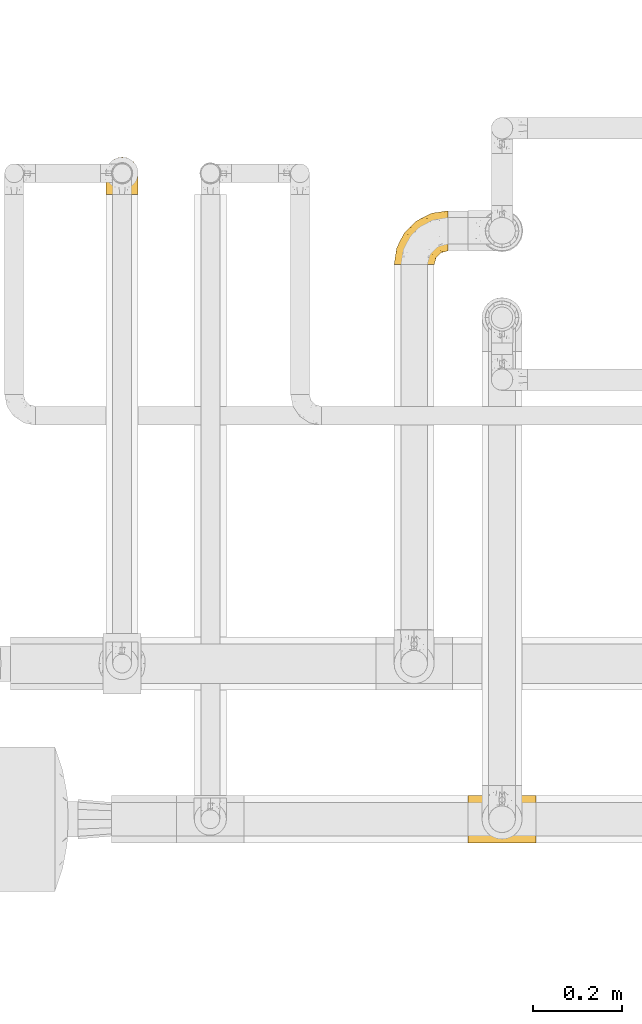
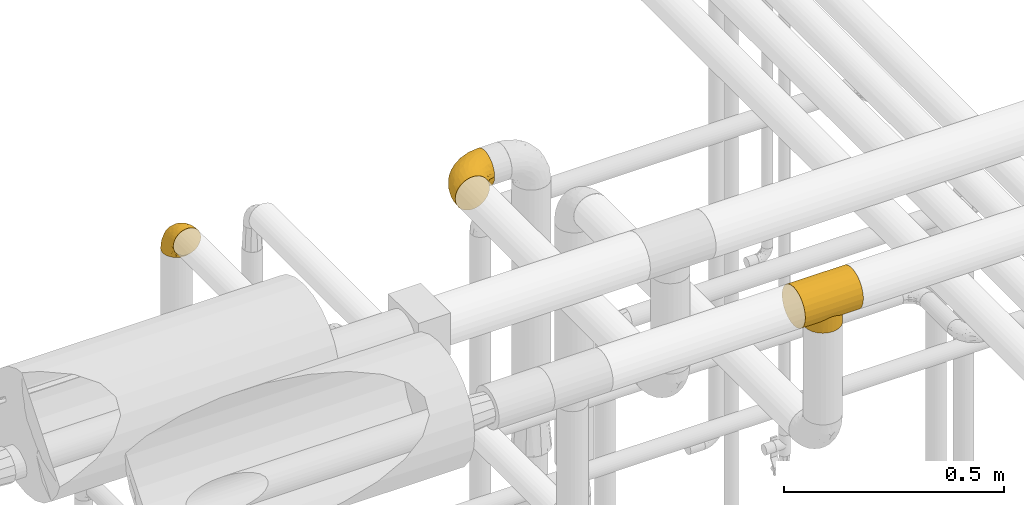
# One storey, part 128 of 827: 3 coverings.
"""IFC2X3 building model written with IfcOpenShell, lengths in millimetres."""

import ifcopenshell
import ifcopenshell.guid

model = None  # the IFC model being written
_history = None  # IfcOwnerHistory: only IFC2X3 demands one
_inside = {}  # id of a spatial element -> (the spatial element, [elements in it])
_under = {}  # id of a project, library or spatial element -> (it, [spatial elements below it])
_declared = {}  # id of a project -> (the project, [libraries it declares])
_typed = {}  # id of a type object -> (the type object, [elements of that type])
_made_of = {}  # id of a material, layer set ... -> (it, [elements and type objects made of it])


def new_model(schema):
    """Start an empty IFC model of exactly this schema.

    Asked for "IFC4X3", IfcOpenShell would pick the latest addendum, in which some entities
    have other attributes; the version numbers below select the first issue.
    IFC2X3 requires an IfcOwnerHistory on every rooted entity: one is made here for all.
    """
    global model, _history
    if schema == "IFC4X3":
        model = ifcopenshell.file(schema_version=(4, 3, 0, 0))
    else:
        model = ifcopenshell.file(schema=schema)
    _inside.clear()
    _under.clear()
    _declared.clear()
    _typed.clear()
    _made_of.clear()
    _history = None
    if model.schema == "IFC2X3":
        org = make("IfcOrganization", Name="unknown")
        user = make(
            "IfcPersonAndOrganization",
            ThePerson=make("IfcPerson", FamilyName="unknown"),
            TheOrganization=org,
        )
        app = make(
            "IfcApplication",
            ApplicationDeveloper=org,
            Version="unknown",
            ApplicationFullName="unknown",
            ApplicationIdentifier="unknown",
        )
        _history = make(
            "IfcOwnerHistory",
            OwningUser=user,
            OwningApplication=app,
            ChangeAction="ADDED",
            CreationDate=0,
        )
    return model


def make(cls, **values):
    """One entity of the class cls with the attributes given. An attribute that is None is left unset."""
    return model.create_entity(
        cls, **{name: value for name, value in values.items() if value is not None}
    )


def entity(cls, *values):
    """Any entity or typed value of the class cls, its attributes in the order of the schema. None: left unset."""
    e = model.create_entity(cls)
    for i, value in enumerate(values):
        if value is not None:
            e[i] = value
    return e


def rooted(cls, **values):
    """An entity with a GlobalId (a new one), such as an element, a storey or a relation."""
    return make(cls, GlobalId=ifcopenshell.guid.new(), OwnerHistory=_history, **values)


def si_unit(unit_type, name, prefix=None):
    """IfcSIUnit, for example si_unit("LENGTHUNIT", "METRE", prefix="MILLI")."""
    return make("IfcSIUnit", UnitType=unit_type, Prefix=prefix, Name=name)


def converted_unit(unit_type, name, factor, base, dimensions=None, offset=None):
    """IfcConversionBasedUnit, such as the inch: factor (a typed value) times the base unit."""
    return make(
        "IfcConversionBasedUnit"
        if offset is None
        else "IfcConversionBasedUnitWithOffset",
        ConversionOffset=offset,
        Dimensions=None
        if dimensions is None
        else entity("IfcDimensionalExponents", *dimensions),
        UnitType=unit_type,
        Name=name,
        ConversionFactor=make(
            "IfcMeasureWithUnit", ValueComponent=factor, UnitComponent=base
        ),
    )


def derived_unit(unit_type, elements):
    """IfcDerivedUnit: a product of units, each with its exponent."""
    return make(
        "IfcDerivedUnit",
        Elements=[
            make("IfcDerivedUnitElement", Unit=unit, Exponent=power)
            for unit, power in elements
        ],
        UnitType=unit_type,
    )


def assignment(units):
    """IfcUnitAssignment: the units of a project."""
    return None if units is None else make("IfcUnitAssignment", Units=units)


def point(xyz):
    """IfcCartesianPoint."""
    return None if xyz is None else make("IfcCartesianPoint", Coordinates=xyz)


def direction(xyz):
    """IfcDirection."""
    return None if xyz is None else make("IfcDirection", DirectionRatios=xyz)


def frame(location, z_axis=None, x_axis=None):
    """IfcAxis2Placement3D, a coordinate frame: its origin and axes. An axis left out is left unset."""
    return make(
        "IfcAxis2Placement3D",
        Location=point(location),
        Axis=direction(z_axis),
        RefDirection=direction(x_axis),
    )


def origin():
    """The frame at (0, 0, 0) with its axes left unset."""
    return frame((0.0, 0.0, 0.0))


def place(relative_to, where):
    """IfcLocalPlacement: puts the frame where relative to a parent placement (None: the world)."""
    return make(
        "IfcLocalPlacement", PlacementRelTo=relative_to, RelativePlacement=where
    )


def context(
    kind, dimensions, precision=None, world=None, true_north=None, identifier=None
):
    """IfcGeometricRepresentationContext, for example the 3D "Model" context."""
    return make(
        "IfcGeometricRepresentationContext",
        ContextIdentifier=identifier,
        ContextType=kind,
        CoordinateSpaceDimension=dimensions,
        Precision=precision,
        WorldCoordinateSystem=world,
        TrueNorth=true_north,
    )


def subcontext(parent, identifier, kind, view, scale=None):
    """IfcGeometricRepresentationSubContext, for example "Body" below "Model"."""
    return make(
        "IfcGeometricRepresentationSubContext",
        ContextIdentifier=identifier,
        ContextType=kind,
        ParentContext=parent,
        TargetScale=scale,
        TargetView=view,
    )


def project(units=None, contexts=None):
    """IfcProject with its units and contexts."""
    return rooted(
        "IfcProject",
        Name="project",
        RepresentationContexts=contexts,
        UnitsInContext=assignment(units),
    )


def spatial(cls, under=None, at=None, **own):
    """A site, building, storey or space (cls), placed at a placement, below another one or the project."""
    s = rooted(cls, ObjectPlacement=at, **own)
    if under is not None:
        _under.setdefault(under.id(), (under, []))[1].append(s)
    return s


def faces_of(points, faces, orient=None, outer=None):
    """IfcFace entities. A face is a list of loops; a loop is a list of indices into points, from 0.

    orient and outer hold one flag for each loop. By default every Orientation is true, the
    first loop of a face is its IfcFaceOuterBound and the others are IfcFaceBound.
    """
    made = []
    for i, loops in enumerate(faces):
        bounds = []
        for j, loop in enumerate(loops):
            is_outer = j == 0 if outer is None else outer[i][j]
            bounds.append(
                make(
                    "IfcFaceOuterBound" if is_outer else "IfcFaceBound",
                    Bound=make("IfcPolyLoop", Polygon=[points[k] for k in loop]),
                    Orientation=True if orient is None else orient[i][j],
                )
            )
        made.append(make("IfcFace", Bounds=bounds))
    return made


def faceted_brep(points, faces, orient=None, outer=None, voids=None):
    """IfcFacetedBrep: a solid bounded by flat faces; with voids (closed shells), ...WithVoids."""
    shared = [point(p) for p in points]
    hull = make("IfcClosedShell", CfsFaces=faces_of(shared, faces, orient, outer))
    if voids is None:
        return make("IfcFacetedBrep", Outer=hull)
    return make(
        "IfcFacetedBrepWithVoids",
        Outer=hull,
        Voids=[
            make(cls, CfsFaces=faces_of(shared, fs, o, b)) for cls, fs, o, b in voids
        ],
    )


def shape(context_of_items, identifier, shape_type, items):
    """IfcShapeRepresentation: the items that make up one representation, for example the "Body"."""
    return make(
        "IfcShapeRepresentation",
        ContextOfItems=context_of_items,
        RepresentationIdentifier=identifier,
        RepresentationType=shape_type,
        Items=items,
    )


def made_of(thing, what):
    """Note that an element or type object is made of a material, layer set ...; save() writes the relation."""
    if what is not None:
        _made_of.setdefault(what.id(), (what, []))[1].append(thing)
    return thing


def element(
    cls,
    number,
    at=None,
    inside=None,
    cuts=None,
    type_object=None,
    material=None,
    context=None,
    identifier="Body",
    shape_type=None,
    held_by="IfcProductDefinitionShape",
    body=None,
    shapes=None,
    **own,
):
    """One element of the class cls, such as IfcWall. Its Tag is "e" and its number.

    at: its placement. inside: the storey or other place that contains it. cuts: it is an
    opening in that element (IfcRelVoidsElement). A single representation is given by context,
    identifier, shape_type and body (its items); several are given by shapes. held_by: the class
    of the entity that holds the representations. save() writes the other relations.
    """
    e = rooted(cls, Tag="e%d" % number, ObjectPlacement=at, **own)
    if body is not None:
        shapes = [shape(context, identifier, shape_type, body)]
    if shapes is not None:
        e.Representation = make(held_by, Representations=shapes)
    if inside is not None:
        _inside.setdefault(inside.id(), (inside, []))[1].append(e)
    if cuts is not None:
        rooted(
            "IfcRelVoidsElement", RelatingBuildingElement=cuts, RelatedOpeningElement=e
        )
    if type_object is not None:
        _typed.setdefault(type_object.id(), (type_object, []))[1].append(e)
    return made_of(e, material)


def aggregate(whole, parts):
    """IfcRelAggregates: a whole, such as a stair, and the parts it consists of."""
    return rooted("IfcRelAggregates", RelatingObject=whole, RelatedObjects=parts)


def save(model, path):
    """Write the relations noted so far, then the file.

    IfcRelAggregates (storeys below a building ...), IfcRelContainedInSpatialStructure (elements
    in a storey), IfcRelDefinesByType, IfcRelAssociatesMaterial and IfcRelDeclares: one each for
    every whole, place, type object, material and project.
    """
    for whole, parts in _under.values():
        aggregate(whole, parts)
    for where, things in _inside.values():
        rooted(
            "IfcRelContainedInSpatialStructure",
            RelatedElements=things,
            RelatingStructure=where,
        )
    for kind, things in _typed.values():
        rooted("IfcRelDefinesByType", RelatedObjects=things, RelatingType=kind)
    for what, things in _made_of.values():
        rooted("IfcRelAssociatesMaterial", RelatedObjects=things, RelatingMaterial=what)
    for by, libraries in _declared.values():
        rooted("IfcRelDeclares", RelatingContext=by, RelatedDefinitions=libraries)
    model.write(path)


model = new_model("IFC2X3")

# Units and contexts
model_context = context("Model", 3, precision=0.01, world=origin(), true_north=direction((6.12303176911189e-17, 1.0)))
body_context = subcontext(model_context, "Body", "Model", "MODEL_VIEW")
ifc_project = project(units=[si_unit("LENGTHUNIT", "METRE", prefix="MILLI"), si_unit("AREAUNIT", "SQUARE_METRE"), si_unit("VOLUMEUNIT", "CUBIC_METRE"), converted_unit("PLANEANGLEUNIT", "DEGREE", entity("IfcRatioMeasure", 0.0174532925199433), si_unit("PLANEANGLEUNIT", "RADIAN"), dimensions=[0, 0, 0, 0, 0, 0, 0]), si_unit("MASSUNIT", "GRAM", prefix="KILO"), derived_unit("MASSDENSITYUNIT", [(si_unit("MASSUNIT", "GRAM", prefix="KILO"), 1), (si_unit("LENGTHUNIT", "METRE"), -3)]), derived_unit("MOMENTOFINERTIAUNIT", [(si_unit("LENGTHUNIT", "METRE"), 4)]), si_unit("TIMEUNIT", "SECOND"), si_unit("FREQUENCYUNIT", "HERTZ"), si_unit("THERMODYNAMICTEMPERATUREUNIT", "DEGREE_CELSIUS"), derived_unit("THERMALTRANSMITTANCEUNIT", [(si_unit("MASSUNIT", "GRAM", prefix="KILO"), 1), (si_unit("THERMODYNAMICTEMPERATUREUNIT", "KELVIN"), -1), (si_unit("TIMEUNIT", "SECOND"), -3)]), derived_unit("VOLUMETRICFLOWRATEUNIT", [(si_unit("LENGTHUNIT", "METRE"), 3), (si_unit("TIMEUNIT", "SECOND"), -1)]), derived_unit("MASSFLOWRATEUNIT", [(si_unit("MASSUNIT", "GRAM", prefix="KILO"), 1), (si_unit("TIMEUNIT", "SECOND"), -1)]), derived_unit("ROTATIONALFREQUENCYUNIT", [(si_unit("TIMEUNIT", "SECOND"), -1)]), si_unit("ELECTRICCURRENTUNIT", "AMPERE"), si_unit("ELECTRICVOLTAGEUNIT", "VOLT"), si_unit("POWERUNIT", "WATT"), si_unit("FORCEUNIT", "NEWTON", prefix="KILO"), si_unit("ILLUMINANCEUNIT", "LUX"), si_unit("LUMINOUSFLUXUNIT", "LUMEN"), si_unit("LUMINOUSINTENSITYUNIT", "CANDELA"), derived_unit("USERDEFINED", [(si_unit("MASSUNIT", "GRAM", prefix="KILO"), -1), (si_unit("LENGTHUNIT", "METRE"), -2), (si_unit("TIMEUNIT", "SECOND"), 3), (si_unit("LUMINOUSFLUXUNIT", "LUMEN"), 1)]), derived_unit("LINEARVELOCITYUNIT", [(si_unit("LENGTHUNIT", "METRE"), 1), (si_unit("TIMEUNIT", "SECOND"), -1)]), si_unit("PRESSUREUNIT", "PASCAL"), derived_unit("USERDEFINED", [(si_unit("LENGTHUNIT", "METRE"), -2), (si_unit("MASSUNIT", "GRAM", prefix="KILO"), 1), (si_unit("TIMEUNIT", "SECOND"), -2)]), derived_unit("LINEARFORCEUNIT", [(si_unit("MASSUNIT", "GRAM", prefix="KILO"), 1), (si_unit("LENGTHUNIT", "METRE"), 1), (si_unit("TIMEUNIT", "SECOND"), -2), (si_unit("LENGTHUNIT", "METRE"), -1)]), derived_unit("PLANARFORCEUNIT", [(si_unit("MASSUNIT", "GRAM", prefix="KILO"), 1), (si_unit("LENGTHUNIT", "METRE"), 1), (si_unit("TIMEUNIT", "SECOND"), -2), (si_unit("LENGTHUNIT", "METRE"), -2)])], contexts=[model_context])

# Site, building, storey
site_placement = place(None, origin())
site = spatial("IfcSite", under=ifc_project, at=site_placement, CompositionType="ELEMENT")
building_placement = place(site_placement, origin())
building = spatial("IfcBuilding", under=site, at=building_placement, CompositionType="ELEMENT")
storey_placement = place(building_placement, frame((0.0, 0.0, 28200.0)))
storey = spatial("IfcBuildingStorey", under=building, at=storey_placement, Name="08", CompositionType="ELEMENT", Elevation=28200.0)

# Coverings
covering_1_placement = place(storey_placement, frame((17846.29, 14345.35, 2729.98)))
element("IfcCovering", 1, at=covering_1_placement, inside=storey, Name=":ADSK_", ObjectType=":ADSK_", PredefinedType="INSULATION", context=body_context, shape_type="Brep", body=[
    faceted_brep([(152.0, 68.38, 121.24), (152.0, 54.65, 123.05), (152.0, 40.91, 121.24), (152.0, 28.12, 115.94), (152.0, 17.13, 107.51), (152.0, 8.7, 96.53), (152.0, 3.4, 83.73), (152.0, 1.6, 70.0), (152.0, 3.4, 56.27), (152.0, 8.7, 43.48), (152.0, 17.13, 32.49), (152.0, 22.63, 28.27), (152.0, 28.12, 24.06), (152.0, 34.52, 21.41), (152.0, 40.91, 18.76), (152.0, 47.78, 17.85), (152.0, 54.65, 16.95), (152.0, 61.51, 17.85), (152.0, 68.38, 18.76), (152.0, 74.77, 21.41), (152.0, 81.17, 24.06), (152.0, 86.66, 28.27), (152.0, 92.16, 32.49), (152.0, 100.59, 43.48), (152.0, 105.89, 56.27), (152.0, 107.7, 70.0), (152.0, 105.89, 83.73), (152.0, 100.59, 96.53), (152.0, 92.16, 107.51), (152.0, 81.17, 115.94), (0.0, 1.6, 70.0), (0.0, 3.4, 83.73), (0.0, 8.7, 96.53), (0.0, 17.13, 107.51), (0.0, 28.12, 115.94), (0.0, 40.91, 121.24), (0.0, 54.65, 123.05), (0.0, 68.38, 121.24), (0.0, 81.17, 115.94), (0.0, 92.16, 107.51), (0.0, 100.59, 96.53), (0.0, 105.89, 83.73), (0.0, 107.7, 70.0), (0.0, 105.89, 56.27), (0.0, 100.59, 43.48), (0.0, 92.16, 32.49), (0.0, 86.66, 28.27), (0.0, 81.17, 24.06), (0.0, 74.77, 21.41), (0.0, 68.38, 18.76), (0.0, 61.51, 17.85), (0.0, 54.65, 16.95), (0.0, 47.78, 17.85), (0.0, 40.91, 18.76), (0.0, 34.52, 21.41), (0.0, 28.12, 24.06), (0.0, 22.63, 28.27), (0.0, 17.13, 32.49), (0.0, 8.7, 43.48), (0.0, 3.4, 56.27), (76.0, 9.5, 42.15), (48.07, 19.17, 30.55), (56.12, 14.11, 35.78), (118.05, 39.05, 19.55), (116.24, 34.17, 21.06), (65.44, 10.75, 40.21), (41.21, 25.86, 25.44), (95.88, 14.11, 35.78), (86.56, 10.75, 40.21), (120.51, 49.29, 17.5), (121.15, 54.65, 16.95), (30.85, 54.65, 16.95), (31.49, 49.29, 17.5), (103.93, 19.17, 30.55), (110.79, 25.86, 25.44), (35.76, 34.17, 21.06), (32.14, 43.94, 18.04), (33.95, 39.05, 19.55), (119.86, 43.94, 18.04), (31.49, 60.0, 17.5), (32.14, 65.35, 18.04), (35.76, 75.12, 21.06), (41.21, 83.43, 25.44), (48.07, 90.12, 30.55), (33.95, 70.24, 19.55), (119.86, 65.35, 18.04), (120.51, 60.0, 17.5), (116.24, 75.12, 21.06), (110.79, 83.43, 25.44), (118.05, 70.24, 19.55), (56.12, 95.18, 35.78), (76.0, 99.8, 42.15), (65.44, 98.54, 40.21), (95.88, 95.18, 35.78), (103.93, 90.12, 30.55), (86.56, 98.54, 40.21), (44.07, 22.72, 0.0), (36.9, 32.07, 0.0), (32.39, 42.96, 0.0), (30.85, 54.65, 0.0), (32.39, 66.33, 0.0), (36.9, 77.22, 0.0), (44.07, 86.57, 0.0), (53.42, 93.75, 0.0), (64.31, 98.26, 0.0), (76.0, 99.8, 0.0), (87.69, 98.26, 0.0), (98.57, 93.75, 0.0), (107.93, 86.57, 0.0), (115.1, 77.22, 0.0), (119.61, 66.33, 0.0), (121.15, 54.65, 0.0), (119.61, 42.96, 0.0), (115.1, 32.07, 0.0), (107.93, 22.72, 0.0), (98.57, 15.54, 0.0), (87.69, 11.03, 0.0), (76.0, 9.5, 0.0), (64.31, 11.03, 0.0), (53.42, 15.54, 0.0)], [[[0, 1, 2, 3, 4, 5, 6, 7, 8, 9, 10, 11, 12, 13, 14, 15, 16, 17, 18, 19, 20, 21, 22, 23, 24, 25, 26, 27, 28, 29]], [[30, 31, 32, 33, 34, 35, 36, 37, 38, 39, 40, 41, 42, 43, 44, 45, 46, 47, 48, 49, 50, 51, 52, 53, 54, 55, 56, 57, 58, 59]], [[34, 33, 4, 3]], [[1, 36, 35, 2]], [[2, 35, 34, 3]], [[5, 32, 31, 6]], [[6, 31, 30, 7]], [[4, 33, 32, 5]], [[59, 8, 7, 30]], [[58, 60, 59]], [[57, 61, 62]], [[57, 56, 61]], [[63, 13, 64]], [[65, 58, 62]], [[61, 56, 66]], [[62, 58, 57]], [[65, 60, 58]], [[8, 60, 9]], [[67, 9, 68]], [[16, 69, 70]], [[71, 72, 51]], [[10, 9, 67]], [[73, 10, 67]], [[74, 12, 11]], [[68, 9, 60]], [[59, 60, 8]], [[75, 55, 54]], [[66, 55, 75]], [[76, 53, 52]], [[54, 53, 77]], [[13, 63, 14]], [[51, 72, 52]], [[76, 52, 72]], [[77, 75, 54]], [[11, 10, 73]], [[53, 76, 77]], [[12, 64, 13]], [[64, 12, 74]], [[15, 78, 69]], [[11, 73, 74]], [[16, 15, 69]], [[15, 14, 78]], [[78, 14, 63]], [[66, 56, 55]], [[50, 79, 51]], [[80, 50, 49]], [[48, 47, 81]], [[82, 81, 47]], [[45, 83, 46]], [[49, 84, 80]], [[50, 80, 79]], [[85, 17, 86]], [[86, 16, 70]], [[51, 79, 71]], [[87, 88, 20]], [[16, 86, 17]], [[18, 89, 19]], [[88, 21, 20]], [[19, 89, 87]], [[82, 47, 46]], [[84, 48, 81]], [[83, 45, 90]], [[83, 82, 46]], [[90, 45, 44]], [[48, 84, 49]], [[91, 44, 43]], [[91, 92, 44]], [[44, 92, 90]], [[43, 42, 25, 24]], [[85, 18, 17]], [[22, 93, 23]], [[87, 20, 19]], [[22, 21, 94]], [[22, 94, 93]], [[93, 95, 23]], [[18, 85, 89]], [[91, 23, 95]], [[23, 91, 24]], [[24, 91, 43]], [[94, 21, 88]], [[26, 41, 40, 27]], [[27, 40, 39, 28]], [[42, 41, 26, 25]], [[29, 38, 37, 0]], [[0, 37, 36, 1]], [[28, 39, 38, 29]], [[96, 97, 98, 99, 100, 101, 102, 103, 104, 105, 106, 107, 108, 109, 110, 111, 112, 113, 114, 115, 116, 117, 118, 119]], [[76, 99, 98]], [[75, 98, 97]], [[99, 76, 72, 71]], [[66, 75, 97]], [[98, 75, 77, 76]], [[97, 96, 66]], [[61, 96, 119]], [[62, 119, 118]], [[65, 118, 117]], [[61, 119, 62]], [[65, 62, 118]], [[60, 65, 117]], [[96, 61, 66]], [[68, 117, 116]], [[67, 116, 115]], [[60, 117, 68]], [[68, 116, 67]], [[115, 73, 67]], [[115, 114, 73]], [[74, 114, 113]], [[64, 113, 112]], [[78, 112, 111]], [[64, 74, 113]], [[111, 70, 69, 78]], [[112, 78, 63, 64]], [[114, 74, 73]], [[85, 111, 110]], [[87, 110, 109]], [[111, 85, 86, 70]], [[88, 87, 109]], [[110, 87, 89, 85]], [[109, 108, 88]], [[94, 108, 107]], [[93, 107, 106]], [[95, 106, 105]], [[94, 107, 93]], [[95, 93, 106]], [[91, 95, 105]], [[108, 94, 88]], [[92, 105, 104]], [[90, 104, 103]], [[91, 105, 92]], [[92, 104, 90]], [[103, 83, 90]], [[103, 102, 83]], [[82, 102, 101]], [[81, 101, 100]], [[80, 100, 99]], [[81, 82, 101]], [[99, 71, 79, 80]], [[100, 80, 84, 81]], [[102, 82, 83]]]),
])
covering_2_placement = place(storey_placement, frame((17678.0, 15644.75, 2353.26)))
element("IfcCovering", 2, at=covering_2_placement, inside=storey, Name=":ADSK_", ObjectType=":ADSK_", PredefinedType="INSULATION", context=body_context, shape_type="Brep", body=[
    faceted_brep([(36.69, 1.6, 90.76), (27.15, 1.6, 87.42), (18.59, 1.62, 82.04), (11.44, 1.63, 74.89), (6.06, 1.65, 66.33), (2.73, 1.67, 56.79), (1.6, 1.69, 46.75), (2.73, 1.71, 36.69), (6.07, 1.73, 27.15), (11.45, 1.75, 18.59), (18.6, 1.76, 11.44), (27.16, 1.77, 6.06), (36.7, 1.78, 2.73), (46.75, 1.78, 1.6), (56.8, 1.78, 2.73), (66.34, 1.77, 6.07), (74.9, 1.76, 11.45), (82.05, 1.75, 18.6), (87.43, 1.73, 27.16), (90.76, 1.71, 36.7), (91.9, 1.69, 46.75), (90.76, 1.67, 56.8), (87.42, 1.65, 66.34), (82.04, 1.63, 74.9), (74.89, 1.62, 82.05), (66.33, 1.6, 87.43), (56.79, 1.6, 90.76), (46.75, 1.6, 91.9), (122.75, 34.1, 35.13), (122.75, 38.63, 24.25), (122.75, 45.83, 14.91), (122.75, 55.19, 7.75), (122.75, 66.09, 3.27), (122.75, 77.78, 1.75), (122.75, 89.46, 3.31), (122.75, 100.34, 7.85), (122.75, 109.68, 15.04), (122.75, 116.83, 24.41), (122.75, 121.32, 35.3), (122.75, 122.84, 46.99), (122.75, 121.28, 58.68), (122.75, 116.74, 69.56), (122.75, 109.55, 78.89), (122.75, 100.18, 86.05), (122.75, 89.28, 90.54), (122.75, 77.6, 92.05), (122.75, 65.91, 90.49), (122.75, 55.03, 85.96), (122.75, 45.7, 78.76), (122.75, 38.54, 69.4), (122.75, 34.05, 58.5), (122.75, 32.54, 46.81), (24.73, 72.9, 46.89), (29.08, 77.25, 55.36), (38.13, 86.3, 46.92), (85.31, 116.91, 46.98), (93.59, 118.56, 54.77), (100.54, 119.32, 46.99), (63.54, 105.2, 59.84), (38.98, 85.43, 62.24), (50.71, 89.37, 72.04), (93.33, 116.19, 62.88), (75.2, 105.11, 71.54), (100.46, 112.19, 73.16), (41.6, 22.96, 91.24), (80.86, 89.92, 86.49), (94.87, 103.41, 81.1), (67.96, 93.63, 79.68), (52.16, 51.42, 90.78), (52.1, 67.72, 86.98), (36.74, 43.54, 87.47), (17.11, 30.94, 76.93), (23.24, 23.59, 83.77), (29.18, 50.09, 81.13), (52.53, 30.68, 91.95), (60.77, 43.01, 91.98), (69.01, 55.34, 92.01), (100.68, 83.48, 91.2), (103.79, 94.96, 87.77), (16.37, 57.37, 56.64), (7.52, 39.13, 46.82), (7.31, 30.72, 60.46), (93.66, 71.81, 92.04), (102.83, 73.63, 92.04), (112.01, 75.46, 92.05), (18.17, 51.62, 67.97), (71.97, 73.13, 90.49), (9.83, 23.21, 69.61), (5.11, 23.89, 46.79), (45.97, 75.62, 80.06), (48.88, 12.33, 91.92), (50.71, 21.51, 91.94), (22.83, 50.49, 75.09), (51.54, 99.7, 46.95), (81.33, 63.57, 92.02), (31.74, 21.27, 88.57), (32.48, 69.58, 72.79), (68.42, 108.3, 46.96), (25.33, 68.48, 63.11), (16.13, 56.01, 46.86), (92.29, 19.42, 66.24), (94.12, 15.83, 56.63), (100.97, 26.2, 59.94), (95.91, 62.78, 91.08), (107.9, 63.65, 90.34), (87.24, 24.37, 76.69), (95.46, 28.5, 71.63), (90.41, 33.56, 80.05), (74.17, 39.47, 89.61), (83.77, 51.05, 90.07), (76.72, 10.96, 81.34), (84.44, 14.58, 74.59), (76.42, 22.23, 84.19), (90.07, 57.05, 90.48), (99.69, 54.01, 87.93), (61.74, 29.19, 91.04), (58.16, 18.86, 90.99), (112.6, 52.85, 85.24), (110.45, 31.54, 58.17), (107.32, 28.4, 46.8), (108.48, 43.03, 78.48), (66.63, 16.91, 88.25), (115.23, 36.03, 66.14), (105.79, 33.96, 68.67), (89.6, 10.03, 63.8), (69.39, 25.94, 88.47), (66.99, 35.62, 90.68), (102.31, 47.47, 83.89), (99.54, 38.29, 78.05), (55.27, 11.7, 91.24), (82.03, 30.15, 83.52), (94.71, 12.21, 46.77), (96.03, 17.11, 46.78), (94.11, 44.41, 84.75), (84.21, 39.84, 86.41), (101.67, 22.76, 46.79), (112.22, 29.72, 46.8), (108.48, 43.16, 15.19), (102.31, 47.62, 9.78), (99.54, 38.42, 15.59), (94.11, 44.56, 8.92), (110.46, 31.59, 35.45), (76.74, 11.1, 12.2), (50.71, 21.69, 1.64), (58.17, 19.03, 2.57), (55.27, 11.89, 2.29), (94.12, 15.87, 36.93), (92.3, 19.49, 27.34), (100.98, 26.26, 33.67), (69.41, 26.12, 5.12), (76.44, 22.38, 9.4), (66.65, 17.08, 5.31), (115.24, 36.11, 27.5), (102.83, 73.82, 1.74), (112.01, 75.64, 1.75), (82.05, 30.28, 10.11), (87.25, 24.49, 16.91), (112.6, 53.01, 8.46), (107.9, 63.83, 3.4), (93.66, 72.0, 1.74), (95.48, 28.6, 21.99), (89.6, 10.09, 29.74), (60.77, 43.19, 1.68), (69.01, 55.52, 1.71), (74.17, 39.64, 4.04), (48.88, 12.52, 1.62), (84.45, 14.69, 18.97), (95.91, 62.96, 2.67), (90.07, 57.23, 3.23), (81.33, 63.76, 1.72), (61.75, 29.38, 2.57), (83.77, 51.23, 3.62), (84.21, 39.99, 7.25), (52.53, 30.86, 1.65), (90.42, 33.68, 13.58), (67.0, 35.79, 2.95), (99.69, 54.17, 5.78), (105.8, 34.05, 24.96), (94.87, 103.55, 12.81), (80.86, 90.09, 7.36), (67.95, 93.76, 14.19), (75.17, 105.2, 22.38), (50.65, 89.42, 21.79), (71.97, 73.31, 3.29), (52.08, 67.85, 6.78), (32.46, 69.64, 20.96), (38.98, 85.49, 31.58), (103.79, 95.13, 6.1), (100.68, 83.66, 2.63), (63.54, 105.25, 34.08), (93.32, 116.26, 31.08), (93.59, 118.6, 39.2), (100.44, 112.3, 20.79), (52.17, 51.59, 2.91), (36.75, 43.69, 6.19), (41.61, 23.13, 2.34), (7.31, 30.78, 33.14), (17.12, 31.06, 16.67), (16.37, 57.42, 37.07), (23.26, 23.74, 9.8), (18.17, 51.69, 25.71), (25.33, 68.54, 30.64), (9.84, 23.3, 23.95), (29.19, 50.23, 12.55), (22.84, 50.6, 18.59), (31.75, 21.43, 5.0), (45.96, 75.72, 13.72), (29.07, 77.27, 38.44)], [[[0, 1, 2, 3, 4, 5, 6, 7, 8, 9, 10, 11, 12, 13, 14, 15, 16, 17, 18, 19, 20, 21, 22, 23, 24, 25, 26, 27]], [[28, 29, 30, 31, 32, 33, 34, 35, 36, 37, 38, 39, 40, 41, 42, 43, 44, 45, 46, 47, 48, 49, 50, 51]], [[52, 53, 54]], [[55, 56, 57]], [[58, 59, 60]], [[61, 62, 63]], [[27, 64, 0]], [[65, 66, 67]], [[41, 40, 61]], [[68, 69, 70]], [[66, 43, 42]], [[63, 42, 41]], [[71, 72, 73]], [[72, 2, 1]], [[68, 74, 75, 76]], [[45, 44, 77]], [[43, 78, 44]], [[79, 80, 81]], [[77, 82, 83, 84, 45]], [[79, 81, 85]], [[71, 2, 72]], [[65, 86, 77]], [[4, 81, 5]], [[66, 65, 78]], [[4, 3, 87]], [[81, 88, 5]], [[63, 66, 42]], [[68, 70, 64]], [[67, 60, 89]], [[71, 3, 2]], [[64, 27, 90, 91, 74]], [[92, 71, 73]], [[40, 57, 56]], [[59, 93, 54]], [[86, 76, 94, 82]], [[1, 0, 95]], [[58, 62, 61]], [[60, 96, 89]], [[85, 81, 87]], [[56, 97, 58]], [[65, 67, 69]], [[87, 81, 4]], [[67, 89, 69]], [[61, 63, 41]], [[95, 72, 1]], [[73, 72, 70]], [[69, 73, 70]], [[73, 89, 96]], [[3, 71, 87]], [[85, 87, 71]], [[58, 61, 56]], [[59, 58, 93]], [[76, 86, 68]], [[69, 89, 73]], [[68, 86, 69]], [[65, 69, 86]], [[68, 64, 74]], [[95, 64, 70]], [[98, 79, 85]], [[79, 52, 99, 80]], [[66, 62, 67]], [[62, 58, 60]], [[62, 60, 67]], [[59, 98, 96]], [[59, 96, 60]], [[96, 85, 92]], [[88, 81, 80]], [[88, 6, 5]], [[66, 63, 62]], [[64, 95, 0]], [[72, 95, 70]], [[77, 44, 78]], [[86, 82, 77]], [[40, 39, 57]], [[96, 98, 85]], [[40, 56, 61]], [[66, 78, 43]], [[77, 78, 65]], [[79, 98, 53]], [[96, 92, 73]], [[85, 71, 92]], [[97, 56, 55]], [[97, 93, 58]], [[53, 98, 59]], [[54, 53, 59]], [[79, 53, 52]], [[100, 101, 102]], [[46, 45, 84, 83]], [[103, 104, 82]], [[82, 104, 83]], [[105, 106, 107]], [[108, 109, 76]], [[110, 111, 112]], [[103, 113, 114]], [[115, 74, 116]], [[48, 47, 117]], [[118, 102, 119]], [[49, 48, 120]], [[74, 91, 116]], [[116, 121, 115]], [[49, 122, 50]], [[123, 106, 102]], [[124, 111, 22]], [[125, 126, 115]], [[23, 22, 111]], [[24, 110, 121]], [[120, 127, 128]], [[90, 26, 129]], [[27, 26, 90]], [[121, 125, 115]], [[24, 121, 25]], [[130, 105, 107]], [[129, 25, 116]], [[21, 20, 131]], [[120, 123, 122]], [[112, 105, 130]], [[50, 118, 51]], [[21, 124, 22]], [[101, 131, 132]], [[117, 120, 48]], [[24, 23, 110]], [[127, 114, 133]], [[75, 108, 76]], [[107, 134, 130]], [[133, 114, 113]], [[129, 116, 91]], [[25, 121, 116]], [[121, 112, 125]], [[75, 74, 115]], [[101, 135, 102]], [[131, 101, 21]], [[101, 100, 124]], [[128, 127, 133]], [[119, 136, 51, 118]], [[104, 47, 46]], [[83, 104, 46]], [[117, 104, 114]], [[101, 124, 21]], [[111, 124, 100]], [[102, 118, 123]], [[133, 134, 107]], [[111, 110, 23]], [[114, 104, 103]], [[94, 76, 109]], [[121, 110, 112]], [[122, 118, 50]], [[134, 109, 108]], [[133, 107, 128]], [[112, 108, 125]], [[126, 125, 108]], [[108, 75, 126]], [[75, 115, 126]], [[109, 134, 133]], [[130, 108, 112]], [[108, 130, 134]], [[105, 112, 111]], [[111, 100, 105]], [[106, 105, 100]], [[102, 106, 100]], [[128, 106, 123]], [[90, 129, 91]], [[25, 129, 26]], [[104, 117, 47]], [[117, 114, 127]], [[82, 94, 103]], [[113, 94, 109]], [[94, 113, 103]], [[133, 113, 109]], [[106, 128, 107]], [[123, 120, 128]], [[120, 122, 49]], [[118, 122, 123]], [[135, 101, 132]], [[135, 119, 102]], [[117, 127, 120]], [[30, 29, 137]], [[138, 139, 140]], [[51, 136, 119, 141]], [[142, 17, 16]], [[143, 144, 145]], [[146, 147, 148]], [[149, 150, 151]], [[152, 29, 28]], [[33, 32, 153, 154]], [[150, 155, 156]], [[157, 31, 30]], [[153, 158, 159]], [[29, 152, 137]], [[148, 141, 119]], [[156, 160, 147]], [[148, 135, 146]], [[137, 138, 157]], [[19, 161, 146]], [[162, 163, 164]], [[14, 13, 165]], [[153, 32, 158]], [[147, 161, 166]], [[18, 17, 166]], [[167, 168, 169]], [[166, 150, 156]], [[151, 150, 142]], [[151, 170, 149]], [[151, 16, 15]], [[171, 140, 172]], [[165, 143, 145]], [[173, 170, 144]], [[142, 166, 17]], [[19, 131, 20]], [[144, 170, 151]], [[18, 161, 19]], [[173, 144, 143]], [[140, 139, 174]], [[171, 164, 163]], [[164, 172, 155]], [[151, 15, 144]], [[145, 15, 14]], [[173, 162, 170]], [[149, 175, 164]], [[19, 146, 131]], [[132, 131, 146]], [[160, 148, 147]], [[159, 158, 167]], [[135, 132, 146]], [[158, 32, 31]], [[157, 158, 31]], [[167, 158, 176]], [[166, 161, 18]], [[146, 161, 147]], [[148, 177, 141]], [[171, 168, 140]], [[171, 163, 169]], [[151, 142, 16]], [[166, 142, 150]], [[152, 141, 177]], [[51, 141, 28]], [[138, 140, 176]], [[172, 140, 174]], [[175, 149, 170]], [[164, 150, 149]], [[170, 162, 175]], [[162, 164, 175]], [[155, 172, 174]], [[171, 172, 164]], [[155, 174, 156]], [[164, 155, 150]], [[160, 156, 174]], [[147, 166, 156]], [[139, 160, 174]], [[148, 160, 177]], [[15, 145, 144]], [[165, 145, 14]], [[137, 157, 30]], [[158, 157, 176]], [[168, 167, 176]], [[169, 159, 167]], [[140, 168, 176]], [[169, 168, 171]], [[137, 177, 139]], [[160, 139, 177]], [[141, 152, 28]], [[137, 152, 177]], [[148, 119, 135]], [[157, 138, 176]], [[139, 138, 137]], [[178, 179, 180]], [[181, 180, 182]], [[179, 183, 184]], [[185, 186, 182]], [[187, 188, 179]], [[188, 33, 154, 153, 159]], [[181, 189, 190]], [[35, 34, 187]], [[191, 38, 190]], [[192, 178, 181]], [[179, 184, 180]], [[192, 190, 37]], [[37, 190, 38]], [[36, 35, 178]], [[54, 93, 186]], [[35, 187, 178]], [[193, 194, 184]], [[195, 173, 143, 165, 13]], [[195, 193, 173]], [[193, 163, 162, 173]], [[13, 12, 195]], [[8, 7, 196]], [[9, 197, 10]], [[198, 80, 99, 52]], [[196, 7, 88]], [[197, 199, 10]], [[182, 189, 181]], [[200, 198, 201]], [[200, 196, 198]], [[9, 8, 202]], [[194, 199, 203]], [[192, 37, 36]], [[80, 196, 88]], [[183, 159, 169, 163]], [[188, 34, 33]], [[202, 200, 197]], [[185, 203, 204]], [[202, 8, 196]], [[10, 199, 11]], [[12, 11, 205]], [[38, 191, 57]], [[189, 97, 191]], [[203, 199, 197]], [[205, 199, 194]], [[204, 203, 197]], [[184, 203, 206]], [[200, 202, 196]], [[197, 9, 202]], [[207, 54, 186]], [[97, 55, 191]], [[194, 203, 184]], [[183, 163, 193]], [[184, 206, 180]], [[183, 193, 184]], [[205, 195, 12]], [[193, 195, 194]], [[80, 198, 196]], [[207, 186, 201]], [[182, 180, 206]], [[181, 178, 180]], [[185, 182, 206]], [[182, 186, 189]], [[203, 185, 206]], [[185, 200, 201]], [[7, 6, 88]], [[178, 192, 36]], [[190, 192, 181]], [[199, 205, 11]], [[195, 205, 194]], [[159, 183, 188]], [[179, 188, 183]], [[57, 191, 55]], [[57, 39, 38]], [[189, 191, 190]], [[188, 187, 34]], [[178, 187, 179]], [[186, 93, 189]], [[197, 200, 204]], [[185, 204, 200]], [[189, 93, 97]], [[207, 198, 52]], [[185, 201, 186]], [[198, 207, 201]], [[54, 207, 52]]]),
])
covering_3_placement = place(storey_placement, frame((17030.57, 15802.19, 2350.4)))
element("IfcCovering", 3, at=covering_3_placement, inside=storey, Name=":ADSK_", ObjectType=":ADSK_", PredefinedType="INSULATION", context=body_context, shape_type="Brep", body=[
    faceted_brep([(74.0, 1.6, 49.6), (73.09, 1.6, 57.65), (70.41, 1.6, 65.31), (66.09, 1.6, 72.17), (60.36, 1.6, 77.9), (53.5, 1.6, 82.21), (45.85, 1.6, 84.89), (37.8, 1.6, 85.8), (29.74, 1.6, 84.89), (22.08, 1.6, 82.21), (15.22, 1.6, 77.89), (9.49, 1.6, 72.16), (5.18, 1.6, 65.3), (2.5, 1.6, 57.65), (1.6, 1.6, 49.6), (2.19, 1.6, 44.33), (2.5, 1.6, 41.54), (3.84, 1.6, 37.71), (5.18, 1.6, 33.88), (9.5, 1.6, 27.02), (15.23, 1.6, 21.29), (22.09, 1.6, 16.98), (29.74, 1.6, 14.3), (37.8, 1.6, 13.4), (45.85, 1.6, 14.3), (53.51, 1.6, 16.98), (60.37, 1.6, 21.3), (66.1, 1.6, 27.03), (70.41, 1.6, 33.89), (71.75, 1.6, 37.72), (73.09, 1.6, 41.54), (73.4, 1.6, 44.33), (28.43, 14.63, 1.6), (19.7, 18.25, 1.6), (12.2, 24.0, 1.6), (9.32, 27.75, 1.6), (6.45, 31.5, 1.6), (4.64, 35.86, 1.6), (2.83, 40.23, 1.6), (2.29, 44.31, 1.6), (1.94, 46.95, 1.6), (1.6, 49.6, 1.6), (2.83, 58.96, 1.6), (6.45, 67.7, 1.6), (12.2, 75.19, 1.6), (19.7, 80.95, 1.6), (28.43, 84.56, 1.6), (37.8, 85.8, 1.6), (47.16, 84.56, 1.6), (55.9, 80.95, 1.6), (63.39, 75.19, 1.6), (69.15, 67.7, 1.6), (72.76, 58.96, 1.6), (74.0, 49.6, 1.6), (73.3, 44.31, 1.6), (72.76, 40.23, 1.6), (70.95, 35.86, 1.6), (69.15, 31.5, 1.6), (66.27, 27.75, 1.6), (63.39, 24.0, 1.6), (55.9, 18.25, 1.6), (47.16, 14.63, 1.6), (37.8, 13.4, 1.6), (50.11, 59.61, 59.61), (37.8, 60.4, 60.4), (46.44, 51.32, 68.25), (37.8, 81.67, 27.61), (44.03, 82.49, 22.94), (37.8, 82.98, 19.4), (47.59, 73.87, 42.09), (57.17, 73.39, 33.53), (50.38, 81.11, 21.38), (58.65, 77.75, 16.47), (73.37, 16.46, 54.23), (71.27, 51.34, 38.23), (70.16, 63.37, 19.11), (66.97, 61.46, 36.76), (73.22, 54.83, 17.03), (74.0, 45.94, 19.96), (74.0, 47.42, 12.51), (74.0, 47.97, 9.78), (74.0, 48.51, 7.05), (64.86, 70.77, 21.71), (70.93, 15.75, 62.55), (45.19, 39.56, 75.89), (48.57, 21.48, 81.72), (54.32, 36.01, 74.04), (72.94, 34.58, 47.66), (74.0, 19.96, 45.94), (74.0, 23.86, 43.34), (74.0, 27.75, 40.74), (74.0, 31.64, 38.14), (74.0, 35.54, 35.54), (68.72, 46.13, 51.41), (73.34, 48.41, 30.21), (67.28, 16.74, 68.91), (61.7, 21.75, 74.03), (55.94, 16.31, 79.54), (37.8, 19.4, 82.98), (53.02, 48.77, 67.24), (57.31, 58.66, 55.48), (74.0, 7.05, 48.51), (74.0, 12.51, 47.42), (64.86, 34.87, 65.49), (59.15, 45.71, 64.99), (70.05, 30.95, 58.95), (55.98, 67.5, 45.7), (37.8, 75.69, 39.35), (63.54, 53.35, 53.72), (61.4, 64.73, 42.9), (37.8, 27.61, 81.67), (37.8, 51.09, 69.71), (37.8, 39.35, 75.69), (74.0, 38.14, 31.64), (74.0, 40.74, 27.75), (74.0, 43.34, 23.86), (37.8, 69.71, 51.09), (70.9, 30.92, 17.47), (69.2, 26.47, 18.36), (65.83, 24.1, 12.71), (73.31, 42.08, 7.84), (67.07, 27.56, 7.85), (62.53, 22.68, 6.14), (52.3, 12.9, 11.2), (54.94, 10.56, 14.99), (46.54, 9.38, 11.85), (72.14, 25.09, 29.62), (70.14, 24.56, 23.5), (73.22, 30.86, 29.66), (59.32, 15.4, 14.49), (56.36, 16.56, 9.51), (48.99, 14.21, 6.6), (58.36, 19.1, 6.61), (66.05, 6.65, 26.46), (61.56, 9.22, 20.83), (68.98, 13.56, 28.69), (73.26, 10.43, 41.38), (70.05, 32.68, 7.16), (73.39, 40.02, 16.97), (70.87, 33.01, 12.64), (61.17, 13.09, 18.4), (71.9, 11.85, 35.97), (65.19, 20.93, 16.38), (37.8, 6.64, 11.31), (46.04, 5.68, 13.68), (52.15, 5.7, 15.78), (66.57, 14.76, 24.06), (37.8, 9.94, 9.94), (73.34, 25.2, 35.3), (72.91, 19.66, 36.41), (37.8, 11.31, 6.64), (72.75, 39.13, 10.52), (66.28, 18.54, 20.86), (73.17, 37.21, 20.48), (72.08, 30.49, 23.69), (17.23, 19.1, 6.61), (26.6, 14.22, 6.59), (13.06, 22.68, 6.13), (1.6, 7.05, 48.51), (1.6, 12.51, 47.42), (29.56, 5.68, 13.67), (20.66, 10.57, 14.98), (23.45, 5.7, 15.78), (14.04, 9.22, 20.82), (1.6, 49.05, 4.32), (1.6, 47.42, 12.51), (1.6, 48.51, 7.05), (19.23, 16.56, 9.51), (23.3, 12.9, 11.19), (16.29, 15.39, 14.48), (8.09, 27.52, 10.19), (4.72, 33.0, 12.64), (5.54, 32.67, 7.16), (3.69, 11.86, 35.96), (2.84, 39.13, 10.52), (2.42, 37.21, 20.47), (4.69, 30.92, 17.47), (3.51, 30.49, 23.68), (2.2, 40.02, 16.97), (29.05, 9.38, 11.85), (2.29, 42.08, 7.84), (9.55, 6.65, 26.45), (14.43, 13.09, 18.39), (2.33, 10.43, 41.37), (9.32, 18.54, 20.85), (3.45, 25.08, 29.62), (5.45, 24.56, 23.5), (10.41, 20.93, 16.36), (2.81, 19.57, 35.87), (6.62, 13.56, 28.67), (1.6, 19.96, 45.94), (9.76, 24.1, 12.7), (9.03, 14.76, 24.04), (2.37, 30.85, 29.66), (4.15, 20.0, 30.95), (2.17, 25.27, 35.8), (1.6, 23.86, 43.34), (1.6, 40.74, 27.75), (1.6, 38.14, 31.64), (1.6, 45.94, 19.96), (1.6, 43.34, 23.86), (6.39, 26.46, 18.36), (1.6, 27.75, 40.74), (1.6, 35.54, 35.54), (1.6, 31.64, 38.14), (4.32, 51.33, 38.23), (2.37, 54.83, 17.03), (2.25, 48.41, 30.2), (16.43, 45.7, 64.98), (18.27, 58.67, 55.47), (12.04, 53.34, 53.71), (8.62, 61.46, 36.76), (6.87, 46.13, 51.4), (10.72, 34.86, 65.48), (2.64, 34.58, 47.66), (25.48, 59.61, 59.61), (19.59, 67.49, 45.69), (5.43, 63.37, 19.11), (31.57, 82.49, 22.94), (25.21, 81.11, 21.39), (5.53, 30.94, 58.94), (16.94, 77.75, 16.47), (10.73, 70.77, 21.71), (18.42, 73.39, 33.54), (21.26, 36.01, 74.04), (27.01, 21.48, 81.72), (30.39, 39.57, 75.89), (2.22, 16.45, 54.23), (13.88, 21.75, 74.02), (8.3, 16.74, 68.9), (28.0, 73.87, 42.09), (29.14, 51.31, 68.25), (22.56, 48.77, 67.24), (19.64, 16.32, 79.54), (14.18, 64.71, 42.91), (4.66, 15.75, 62.54)], [[[0, 1, 2, 3, 4, 5, 6, 7, 8, 9, 10, 11, 12, 13, 14, 15, 16, 17, 18, 19, 20, 21, 22, 23, 24, 25, 26, 27, 28, 29, 30, 31]], [[32, 33, 34, 35, 36, 37, 38, 39, 40, 41, 42, 43, 44, 45, 46, 47, 48, 49, 50, 51, 52, 53, 54, 55, 56, 57, 58, 59, 60, 61, 62]], [[63, 64, 65]], [[66, 67, 68]], [[69, 70, 71]], [[71, 70, 72]], [[73, 1, 0]], [[74, 75, 76]], [[49, 48, 71]], [[77, 78, 79, 80, 81, 53]], [[50, 82, 51]], [[72, 50, 49]], [[2, 1, 83]], [[84, 85, 86]], [[87, 88, 89, 90, 91, 92]], [[53, 52, 77]], [[93, 74, 76]], [[5, 85, 6]], [[94, 78, 77]], [[95, 3, 2]], [[95, 96, 3]], [[75, 51, 82]], [[85, 5, 97]], [[50, 72, 82]], [[97, 5, 4]], [[85, 98, 6]], [[94, 87, 92]], [[74, 77, 75]], [[99, 100, 63]], [[96, 4, 3]], [[73, 0, 101, 102, 88]], [[96, 103, 104]], [[48, 68, 67]], [[84, 99, 65]], [[105, 83, 73]], [[105, 95, 83]], [[100, 106, 63]], [[86, 96, 104]], [[97, 86, 85]], [[67, 107, 69]], [[100, 108, 109]], [[84, 110, 85]], [[93, 87, 74]], [[96, 95, 103]], [[69, 71, 67]], [[70, 69, 106]], [[4, 96, 97]], [[86, 97, 96]], [[83, 95, 2]], [[103, 95, 105]], [[93, 103, 105]], [[103, 108, 104]], [[75, 77, 52]], [[94, 77, 74]], [[51, 75, 52]], [[75, 82, 76]], [[109, 82, 70]], [[93, 76, 108]], [[88, 87, 73]], [[105, 73, 87]], [[84, 86, 99]], [[84, 111, 112, 110]], [[98, 85, 110]], [[98, 7, 6]], [[73, 83, 1]], [[71, 72, 49]], [[82, 72, 70]], [[87, 94, 74]], [[94, 92, 113, 114, 115, 78]], [[48, 47, 68]], [[48, 67, 71]], [[100, 104, 108]], [[99, 86, 104]], [[109, 108, 76]], [[100, 109, 106]], [[82, 109, 76]], [[106, 109, 70]], [[100, 99, 104]], [[99, 63, 65]], [[69, 116, 63]], [[111, 84, 65]], [[64, 63, 116]], [[64, 111, 65]], [[63, 106, 69]], [[103, 93, 108]], [[87, 93, 105]], [[107, 67, 66]], [[107, 116, 69]], [[117, 118, 119]], [[80, 120, 55]], [[121, 119, 122]], [[120, 56, 55]], [[123, 124, 125]], [[126, 127, 128]], [[101, 0, 31, 30, 102]], [[123, 129, 124]], [[130, 123, 131]], [[60, 122, 132]], [[133, 134, 135]], [[29, 28, 136]], [[132, 61, 60]], [[122, 60, 59]], [[137, 138, 139]], [[124, 129, 140]], [[133, 27, 26]], [[132, 131, 61]], [[141, 136, 28]], [[102, 29, 136]], [[119, 118, 142]], [[58, 137, 121]], [[141, 28, 27]], [[54, 53, 81, 80, 55]], [[23, 143, 144]], [[24, 145, 25]], [[25, 145, 134]], [[26, 25, 134]], [[135, 134, 146]], [[125, 143, 147]], [[124, 144, 125]], [[148, 90, 149]], [[124, 145, 144]], [[150, 125, 147]], [[151, 57, 56]], [[138, 78, 115]], [[131, 62, 61]], [[133, 141, 27]], [[127, 126, 152]], [[141, 135, 149]], [[149, 89, 141]], [[120, 78, 151]], [[115, 153, 138]], [[138, 137, 151]], [[78, 120, 80, 79]], [[151, 56, 120]], [[154, 114, 113]], [[153, 117, 139]], [[145, 24, 144]], [[134, 145, 124]], [[126, 91, 148]], [[146, 126, 135]], [[23, 144, 24]], [[143, 125, 144]], [[131, 125, 150]], [[129, 123, 130]], [[142, 130, 119]], [[124, 140, 134]], [[125, 131, 123]], [[62, 131, 150]], [[129, 152, 140]], [[146, 140, 152]], [[127, 152, 142]], [[153, 115, 114]], [[117, 153, 154]], [[118, 117, 154]], [[121, 117, 119]], [[139, 138, 153]], [[78, 138, 151]], [[127, 118, 154]], [[118, 127, 142]], [[152, 129, 142]], [[130, 142, 129]], [[102, 30, 29]], [[141, 88, 136]], [[88, 102, 136]], [[134, 133, 26]], [[141, 133, 135]], [[121, 122, 59]], [[132, 119, 130]], [[121, 59, 58]], [[121, 139, 117]], [[137, 58, 57]], [[151, 137, 57]], [[121, 137, 139]], [[119, 132, 122]], [[132, 130, 131]], [[140, 146, 134]], [[126, 146, 152]], [[89, 149, 90]], [[89, 88, 141]], [[148, 135, 126]], [[135, 148, 149]], [[114, 154, 153]], [[126, 128, 91]], [[91, 90, 148]], [[92, 128, 113]], [[128, 127, 154]], [[113, 128, 154]], [[91, 128, 92]], [[155, 32, 156]], [[33, 157, 34]], [[62, 150, 156]], [[15, 14, 158, 159, 16]], [[160, 23, 22]], [[161, 162, 163]], [[164, 41, 40, 39, 38, 165, 166]], [[167, 168, 169]], [[157, 170, 34]], [[171, 172, 170]], [[18, 173, 19]], [[174, 37, 36]], [[175, 176, 177]], [[178, 171, 175]], [[147, 179, 150]], [[168, 179, 161]], [[161, 160, 162]], [[162, 160, 22]], [[38, 37, 180]], [[20, 19, 181]], [[21, 20, 163]], [[161, 182, 169]], [[18, 183, 173]], [[184, 185, 186]], [[169, 187, 167]], [[188, 189, 173]], [[159, 190, 183]], [[17, 159, 183]], [[156, 179, 168]], [[191, 157, 155]], [[192, 163, 189]], [[21, 162, 22]], [[147, 143, 179]], [[181, 163, 20]], [[177, 186, 193]], [[178, 172, 171]], [[167, 156, 168]], [[185, 194, 195]], [[181, 173, 189]], [[173, 196, 188]], [[197, 177, 198]], [[199, 165, 180]], [[180, 165, 38]], [[200, 178, 175]], [[37, 174, 180]], [[199, 180, 174]], [[175, 197, 200]], [[177, 176, 201]], [[163, 162, 21]], [[160, 161, 179]], [[192, 185, 184]], [[194, 189, 188]], [[179, 143, 160]], [[23, 160, 143]], [[169, 168, 161]], [[155, 156, 167]], [[182, 161, 163]], [[184, 186, 187]], [[62, 156, 32]], [[179, 156, 150]], [[192, 182, 163]], [[184, 169, 182]], [[176, 175, 171]], [[174, 178, 199]], [[197, 175, 177]], [[170, 176, 171]], [[201, 176, 191]], [[199, 178, 200]], [[178, 174, 172]], [[187, 201, 191]], [[201, 187, 186]], [[167, 187, 191]], [[169, 184, 187]], [[173, 183, 190]], [[17, 16, 159]], [[173, 181, 19]], [[163, 181, 189]], [[155, 157, 33]], [[170, 157, 191]], [[176, 170, 191]], [[35, 170, 172]], [[35, 172, 36]], [[34, 170, 35]], [[174, 36, 172]], [[32, 155, 33]], [[191, 155, 167]], [[192, 189, 194]], [[182, 192, 184]], [[193, 198, 177]], [[183, 18, 17]], [[196, 173, 190]], [[196, 202, 188]], [[193, 186, 185]], [[201, 186, 177]], [[188, 195, 194]], [[203, 193, 204]], [[188, 202, 195]], [[192, 194, 185]], [[202, 204, 195]], [[185, 195, 204]], [[204, 193, 185]], [[198, 193, 203]], [[205, 206, 207]], [[208, 209, 210]], [[210, 211, 212]], [[210, 213, 208]], [[214, 203, 204, 202, 196, 190]], [[206, 41, 164, 166, 165, 199]], [[215, 216, 209]], [[206, 217, 42]], [[218, 46, 219]], [[207, 214, 205]], [[212, 214, 220]], [[221, 219, 45]], [[45, 219, 46]], [[221, 222, 223]], [[224, 225, 226]], [[222, 44, 43]], [[222, 217, 211]], [[220, 214, 227]], [[227, 190, 159, 158, 14]], [[217, 43, 42]], [[14, 13, 227]], [[225, 9, 8]], [[10, 228, 11]], [[11, 229, 12]], [[208, 213, 228]], [[228, 229, 11]], [[230, 219, 223]], [[231, 232, 226]], [[231, 64, 215]], [[225, 233, 9]], [[229, 213, 220]], [[233, 10, 9]], [[110, 225, 98]], [[41, 206, 42]], [[222, 211, 234]], [[224, 228, 233]], [[225, 8, 98]], [[221, 45, 44]], [[226, 110, 112, 111]], [[12, 229, 235]], [[46, 218, 68]], [[230, 107, 218]], [[223, 234, 216]], [[107, 66, 218]], [[224, 233, 225]], [[228, 10, 233]], [[213, 229, 228]], [[235, 229, 220]], [[208, 228, 224]], [[212, 213, 210]], [[207, 206, 199]], [[205, 211, 217]], [[205, 217, 206]], [[43, 217, 222]], [[212, 211, 205]], [[210, 209, 234]], [[227, 13, 235]], [[214, 190, 227]], [[110, 226, 225]], [[232, 231, 215]], [[8, 7, 98]], [[227, 235, 220]], [[13, 12, 235]], [[222, 221, 44]], [[219, 221, 223]], [[207, 199, 200, 197, 198, 203]], [[214, 207, 203]], [[68, 218, 66]], [[68, 47, 46]], [[230, 218, 219]], [[224, 232, 208]], [[208, 232, 209]], [[216, 215, 230]], [[210, 234, 211]], [[216, 234, 209]], [[222, 234, 223]], [[226, 232, 224]], [[209, 232, 215]], [[226, 111, 231]], [[64, 116, 215]], [[231, 111, 64]], [[116, 230, 215]], [[230, 223, 216]], [[214, 212, 205]], [[213, 212, 220]], [[230, 116, 107]]]),
])

save(model, "model.ifc")
